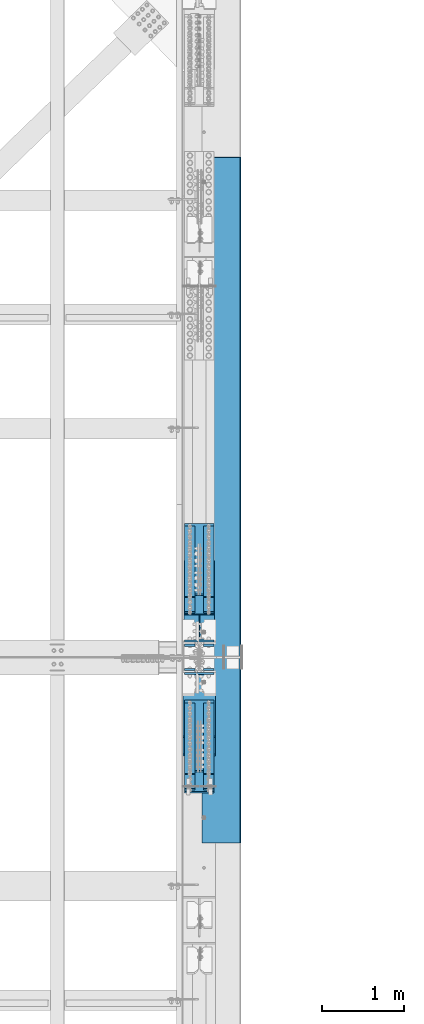
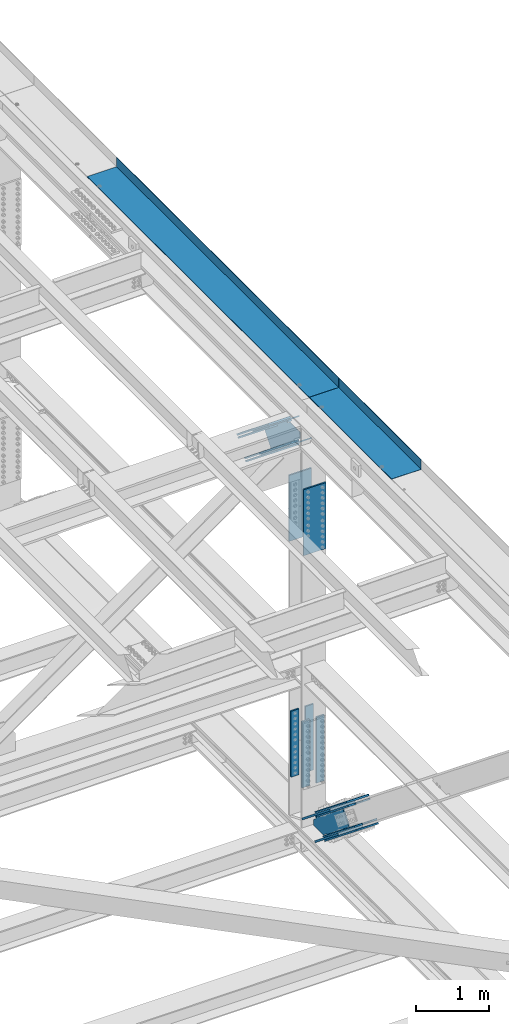
# One storey, part 1966 of 3843: 14 members, 8 beams, 4 elements without a shape of their own.
"""IFC2X3 building model written with IfcOpenShell, lengths in millimetres."""

from ifc_helpers import new_model, si_unit, frame, origin_with_axes, place, context, subcontext, project, spatial, faceted_brep, material, type_object, element, aggregate, save


model = new_model("IFC2X3")

# Units and contexts
model_context = context("Model", 3, precision=1e-05, world=origin_with_axes())
body_context = subcontext(model_context, "Body", "Model", "MODEL_VIEW")
ifc_project = project(units=[si_unit("LENGTHUNIT", "METRE", prefix="MILLI"), si_unit("AREAUNIT", "SQUARE_METRE"), si_unit("VOLUMEUNIT", "CUBIC_METRE"), si_unit("MASSUNIT", "GRAM", prefix="KILO"), si_unit("TIMEUNIT", "SECOND"), si_unit("PLANEANGLEUNIT", "RADIAN"), si_unit("SOLIDANGLEUNIT", "STERADIAN"), si_unit("THERMODYNAMICTEMPERATUREUNIT", "DEGREE_CELSIUS"), si_unit("LUMINOUSINTENSITYUNIT", "LUMEN")], contexts=[model_context])

# Site, building, storey
site_placement = place(None, origin_with_axes())
site = spatial("IfcSite", under=ifc_project, at=site_placement, CompositionType="ELEMENT")
building_placement = place(site_placement, origin_with_axes())
building = spatial("IfcBuilding", under=site, at=building_placement, Name="Undefined", CompositionType="ELEMENT")
storey_placement = place(building_placement, origin_with_axes())
storey = spatial("IfcBuildingStorey", under=building, at=storey_placement, Name="Undefined", CompositionType="ELEMENT", Elevation=0.0)

# Assembly, members
assembly_1_placement = place(storey_placement, origin_with_axes())
assembly_1 = element("IfcElementAssembly", 1, at=assembly_1_placement, inside=storey, Name="BEAM", AssemblyPlace="NOTDEFINED", PredefinedType="RIGID_FRAME")
ifc_material_1 = material(Name="STEEL/A572-50")
member_type_1 = type_object("IfcMemberType", PredefinedType="NOTDEFINED")
member_1_placement = place(assembly_1_placement, frame((85534.5, 43611.4163154636, 44972.4352505098), z_axis=(1.0, 0.0, 0.0), x_axis=(0.0, -0.777700934239512, 0.628634438193605)))
member_1 = element("IfcMember", 2, at=member_1_placement, type_object=member_type_1, material=ifc_material_1, Name="PLATE", context=body_context, shape_type="Brep", body=[
    faceted_brep([(-4.36557456851006e-11, 12.7000000000116, -63.5), (-4.36557456851006e-11, 12.7000000000116, 63.5), (1104.90000001677, 12.7000000017251, 63.5), (1104.90000001677, 12.7000000017251, -63.5), (1.45519152283669e-11, -12.700000000008, 63.5), (1104.90000001682, -12.6999999982909, 63.5), (1.45519152283669e-11, -12.700000000008, -63.5), (1104.90000001682, -12.6999999982909, -63.5)], [[[0, 1, 2, 3]], [[1, 4, 5, 2]], [[4, 6, 7, 5]], [[6, 0, 3, 7]], [[5, 7, 3, 2]], [[6, 4, 1, 0]]]),
])
member_2_placement = place(assembly_1_placement, frame((85534.5, 43797.0363489544, 45202.0708938554), z_axis=(1.0, 0.0, 0.0), x_axis=(0.0, -0.777700934239512, 0.628634438193605)))
member_2 = element("IfcMember", 3, at=member_2_placement, type_object=member_type_1, material=ifc_material_1, Name="PLATE", context=body_context, shape_type="Brep", body=[
    faceted_brep([(-4.36557456851006e-11, 12.7000000000116, -63.5), (-4.36557456851006e-11, 12.7000000000116, 63.5), (1104.90000001677, 12.7000000017251, 63.5), (1104.90000001677, 12.7000000017251, -63.5), (1.45519152283669e-11, -12.700000000008, 63.5), (1104.90000001682, -12.6999999982909, 63.5), (1.45519152283669e-11, -12.700000000008, -63.5), (1104.90000001682, -12.6999999982909, -63.5)], [[[0, 1, 2, 3]], [[1, 4, 5, 2]], [[4, 6, 7, 5]], [[6, 0, 3, 7]], [[5, 7, 3, 2]], [[6, 4, 1, 0]]]),
])
member_3_placement = place(assembly_1_placement, frame((85763.1, 43611.4163154636, 44972.4352505098), z_axis=(1.0, 0.0, 0.0), x_axis=(0.0, -0.777700934239512, 0.628634438193605)))
member_3 = element("IfcMember", 4, at=member_3_placement, type_object=member_type_1, material=ifc_material_1, Name="PLATE", context=body_context, shape_type="Brep", body=[
    faceted_brep([(-4.36557456851006e-11, 12.7000000000116, -63.5), (-4.36557456851006e-11, 12.7000000000116, 63.5), (1104.90000001677, 12.7000000017251, 63.5), (1104.90000001677, 12.7000000017251, -63.5), (1.45519152283669e-11, -12.700000000008, 63.5), (1104.90000001682, -12.6999999982909, 63.5), (1.45519152283669e-11, -12.700000000008, -63.5), (1104.90000001682, -12.6999999982909, -63.5)], [[[0, 1, 2, 3]], [[1, 4, 5, 2]], [[4, 6, 7, 5]], [[6, 0, 3, 7]], [[5, 7, 3, 2]], [[6, 4, 1, 0]]]),
])
member_4_placement = place(assembly_1_placement, frame((85763.1, 43797.0363489544, 45202.0708938554), z_axis=(1.0, 0.0, 0.0), x_axis=(0.0, -0.777700934239512, 0.628634438193605)))
member_4 = element("IfcMember", 5, at=member_4_placement, type_object=member_type_1, material=ifc_material_1, Name="PLATE", context=body_context, shape_type="Brep", body=[
    faceted_brep([(-4.36557456851006e-11, 12.7000000000116, -63.5), (-4.36557456851006e-11, 12.7000000000116, 63.5), (1104.90000001677, 12.7000000017251, 63.5), (1104.90000001677, 12.7000000017251, -63.5), (1.45519152283669e-11, -12.700000000008, 63.5), (1104.90000001682, -12.6999999982909, 63.5), (1.45519152283669e-11, -12.700000000008, -63.5), (1104.90000001682, -12.6999999982909, -63.5)], [[[0, 1, 2, 3]], [[1, 4, 5, 2]], [[4, 6, 7, 5]], [[6, 0, 3, 7]], [[5, 7, 3, 2]], [[6, 4, 1, 0]]]),
])

assembly_2_placement = place(storey_placement, origin_with_axes())
assembly_2 = element("IfcElementAssembly", 6, at=assembly_2_placement, inside=storey, Name="BEAM", AssemblyPlace="NOTDEFINED", PredefinedType="RIGID_FRAME")
member_5_placement = place(assembly_2_placement, frame((85763.1, 40594.7050881366, 40636.5082633832), z_axis=(-1.0, 0.0, 0.0), x_axis=(0.0, 0.778233356227861, -0.62797519318387)))
member_5 = element("IfcMember", 7, at=member_5_placement, type_object=member_type_1, material=ifc_material_1, Name="PLATE", context=body_context, shape_type="Brep", body=[
    faceted_brep([(-4.36557456851006e-11, 12.7000000000116, -63.5), (-4.36557456851006e-11, 12.7000000000116, 63.5), (1104.90000001677, 12.7000000017251, 63.5), (1104.90000001677, 12.7000000017251, -63.5), (1.45519152283669e-11, -12.700000000008, 63.5), (1104.90000001682, -12.6999999982909, 63.5), (1.45519152283669e-11, -12.700000000008, -63.5), (1104.90000001682, -12.6999999982909, -63.5)], [[[0, 1, 2, 3]], [[1, 4, 5, 2]], [[4, 6, 7, 5]], [[6, 0, 3, 7]], [[5, 7, 3, 2]], [[6, 4, 1, 0]]]),
])
member_6_placement = place(assembly_2_placement, frame((85763.1, 40780.1304631424, 40866.3011174421), z_axis=(-1.0, 0.0, 0.0), x_axis=(0.0, 0.778233356227861, -0.62797519318387)))
member_6 = element("IfcMember", 8, at=member_6_placement, type_object=member_type_1, material=ifc_material_1, Name="PLATE", context=body_context, shape_type="Brep", body=[
    faceted_brep([(-4.36557456851006e-11, 12.7000000000116, -63.5), (-4.36557456851006e-11, 12.7000000000116, 63.5), (1104.90000001677, 12.7000000017251, 63.5), (1104.90000001677, 12.7000000017251, -63.5), (1.45519152283669e-11, -12.700000000008, 63.5), (1104.90000001682, -12.6999999982909, 63.5), (1.45519152283669e-11, -12.700000000008, -63.5), (1104.90000001682, -12.6999999982909, -63.5)], [[[0, 1, 2, 3]], [[1, 4, 5, 2]], [[4, 6, 7, 5]], [[6, 0, 3, 7]], [[5, 7, 3, 2]], [[6, 4, 1, 0]]]),
])
member_7_placement = place(assembly_2_placement, frame((85534.5, 40594.7050881365, 40636.508263383), z_axis=(-1.0, 0.0, 0.0), x_axis=(0.0, 0.778233356227861, -0.62797519318387)))
member_7 = element("IfcMember", 9, at=member_7_placement, type_object=member_type_1, material=ifc_material_1, Name="PLATE", context=body_context, shape_type="Brep", body=[
    faceted_brep([(-4.36557456851006e-11, 12.7000000000116, -63.5), (-4.36557456851006e-11, 12.7000000000116, 63.5), (1104.90000001677, 12.7000000017251, 63.5), (1104.90000001677, 12.7000000017251, -63.5), (1.45519152283669e-11, -12.700000000008, 63.5), (1104.90000001682, -12.6999999982909, 63.5), (1.45519152283669e-11, -12.700000000008, -63.5), (1104.90000001682, -12.6999999982909, -63.5)], [[[0, 1, 2, 3]], [[1, 4, 5, 2]], [[4, 6, 7, 5]], [[6, 0, 3, 7]], [[5, 7, 3, 2]], [[6, 4, 1, 0]]]),
])
member_8_placement = place(assembly_2_placement, frame((85534.5, 40780.1304626162, 40866.30111679), z_axis=(-1.0, 0.0, 0.0), x_axis=(0.0, 0.778233356227861, -0.62797519318387)))
member_8 = element("IfcMember", 10, at=member_8_placement, type_object=member_type_1, material=ifc_material_1, Name="PLATE", context=body_context, shape_type="Brep", body=[
    faceted_brep([(-4.36557456851006e-11, 12.7000000000116, -63.5), (-4.36557456851006e-11, 12.7000000000116, 63.5), (1104.90000001677, 12.7000000017251, 63.5), (1104.90000001677, 12.7000000017251, -63.5), (1.45519152283669e-11, -12.700000000008, 63.5), (1104.90000001682, -12.6999999982909, 63.5), (1.45519152283669e-11, -12.700000000008, -63.5), (1104.90000001682, -12.6999999982909, -63.5)], [[[0, 1, 2, 3]], [[1, 4, 5, 2]], [[4, 6, 7, 5]], [[6, 0, 3, 7]], [[5, 7, 3, 2]], [[6, 4, 1, 0]]]),
])

# Member
member_type_2 = type_object("IfcMemberType", PredefinedType="NOTDEFINED")
member_9_placement = place(assembly_1_placement, frame((85648.8, 42724.1917519318, 45632.4446340601), z_axis=(1.0, 0.0, 0.0), x_axis=(0.0, 0.777700934239514, -0.628634438193604)))
member_9 = element("IfcMember", 11, at=member_9_placement, type_object=member_type_2, material=ifc_material_1, Name="PLATE", context=body_context, shape_type="Brep", body=[
    faceted_brep([(-1.45519152283669e-11, 12.7000000000025, -177.800000000003), (-1.45519152283669e-11, 12.7000000000025, 177.800000000003), (1104.90000001682, 12.7000000017051, 177.800000000003), (1104.90000001682, 12.7000000017051, -177.800000000003), (4.36557456851006e-11, -12.7000000000171, 177.800000000003), (1104.90000001686, -12.6999999983072, 177.800000000003), (4.36557456851006e-11, -12.7000000000171, -177.800000000003), (1104.90000001686, -12.6999999983072, -177.800000000003)], [[[0, 1, 2, 3]], [[1, 4, 5, 2]], [[4, 6, 7, 5]], [[6, 0, 3, 7]], [[5, 7, 3, 2]], [[6, 4, 1, 0]]]),
])

member_10_placement = place(assembly_1_placement, frame((85648.8, 42965.6973871403, 45931.2178907486), z_axis=(1.0, 0.0, 0.0), x_axis=(0.0, 0.777700934239514, -0.628634438193604)))
member_10 = element("IfcMember", 12, at=member_10_placement, type_object=member_type_2, material=ifc_material_1, Name="PLATE", context=body_context, shape_type="Brep", body=[
    faceted_brep([(-1.45519152283669e-11, 12.7000000000025, -177.800000000003), (-1.45519152283669e-11, 12.7000000000025, 177.800000000003), (1104.90000001682, 12.7000000017051, 177.800000000003), (1104.90000001682, 12.7000000017051, -177.800000000003), (4.36557456851006e-11, -12.7000000000171, 177.800000000003), (1104.90000001686, -12.6999999983072, 177.800000000003), (4.36557456851006e-11, -12.7000000000171, -177.800000000003), (1104.90000001686, -12.6999999983072, -177.800000000003)], [[[0, 1, 2, 3]], [[1, 4, 5, 2]], [[4, 6, 7, 5]], [[6, 0, 3, 7]], [[5, 7, 3, 2]], [[6, 4, 1, 0]]]),
])

member_11_placement = place(assembly_2_placement, frame((85648.8, 41419.6832516066, 39899.4178813601), z_axis=(-1.0, 0.0, 0.0), x_axis=(0.0, -0.778233356227861, 0.62797519318387)))
member_11 = element("IfcMember", 13, at=member_11_placement, type_object=member_type_2, material=ifc_material_1, Name="PLATE", context=body_context, shape_type="Brep", body=[
    faceted_brep([(-1.45519152283669e-11, 12.7000000000025, -177.800000000003), (-1.45519152283669e-11, 12.7000000000025, 177.800000000003), (1104.90000001682, 12.7000000017051, 177.800000000003), (1104.90000001682, 12.7000000017051, -177.800000000003), (4.36557456851006e-11, -12.7000000000171, 177.800000000003), (1104.90000001686, -12.6999999983072, 177.800000000003), (4.36557456851006e-11, -12.7000000000171, -177.800000000003), (1104.90000001686, -12.6999999983072, -177.800000000003)], [[[0, 1, 2, 3]], [[1, 4, 5, 2]], [[4, 6, 7, 5]], [[6, 0, 3, 7]], [[5, 7, 3, 2]], [[6, 4, 1, 0]]]),
])

member_12_placement = place(assembly_2_placement, frame((85648.8, 41674.892370288, 40215.6919175422), z_axis=(-1.0, 0.0, 0.0), x_axis=(0.0, -0.778233356227861, 0.62797519318387)))
member_12 = element("IfcMember", 14, at=member_12_placement, type_object=member_type_2, material=ifc_material_1, Name="PLATE", context=body_context, shape_type="Brep", body=[
    faceted_brep([(-1.45519152283669e-11, 12.7000000000025, -177.800000000003), (-1.45519152283669e-11, 12.7000000000025, 177.800000000003), (1104.90000001682, 12.7000000017051, 177.800000000003), (1104.90000001682, 12.7000000017051, -177.800000000003), (4.36557456851006e-11, -12.7000000000171, 177.800000000003), (1104.90000001686, -12.6999999983072, 177.800000000003), (4.36557456851006e-11, -12.7000000000171, -177.800000000003), (1104.90000001686, -12.6999999983072, -177.800000000003)], [[[0, 1, 2, 3]], [[1, 4, 5, 2]], [[4, 6, 7, 5]], [[6, 0, 3, 7]], [[5, 7, 3, 2]], [[6, 4, 1, 0]]]),
])

ifc_material_2 = material(Name="STEEL/A992")
member_type_3 = type_object("IfcMemberType", Name="W14X99", PredefinedType="NOTDEFINED")
member_13_placement = place(assembly_1_placement, frame((85648.8, 43274.5854509239, 45434.542167357), z_axis=(0.0, 0.628634438193607, 0.777700934239511), x_axis=(0.0, -0.777700934239512, 0.628634438193605)))
member_13 = element("IfcMember", 15, at=member_13_placement, type_object=member_type_3, material=ifc_material_2, Name="BEAM", ObjectType="W14X99", context=body_context, shape_type="Brep", body=[
    faceted_brep([(981.500451003007, 6.35000000000582, -160.337499995949), (991.140102408519, 6.35000000000582, -160.321113912411), (991.140094901422, 6.35000000000582, -160.33749999592), (981.500451003007, 185.737500000003, -160.337499995949), (991.140094901422, 185.737500000003, -160.33749999592), (6.35000000639411, -185.737500000003, 160.337500001014), (6.35000000639411, -6.35000000000582, 160.337500001014), (802.375273800926, -6.35000000000582, 160.337500003203), (802.375273800926, -185.737500000003, 160.337500003203), (967.470718106835, -6.35000000000582, -131.8375449792), (967.470718106835, 6.35000000000582, -131.8375449792), (1013.46312808303, 6.35000000000582, -131.815463325067), (1029.79451188982, -6.35000000000582, -131.807622379827), (962.434567453738, -6.35000000000582, -133.280667367828), (962.434567453738, 6.35000000000582, -133.280667367828), (958.923286642619, -6.35000000000582, -137.168638907693), (958.923286642619, 6.35000000000582, -137.168638907693), (957.999073580324, -6.35000000000582, -142.325308942192), (957.999073580324, 6.35000000000582, -142.325308942192), (959.941512052095, -6.35000000000582, -147.19073270716), (959.941512052095, 6.35000000000582, -147.19073270716), (6.35000000674336, 185.737500000003, -160.33750000099), (6.35000000674336, 6.35000000000582, -160.33750000099), (970.111951838846, 6.35000000000582, -160.337499996007), (970.111951838846, 185.737500000003, -160.337499996007), (790.036726578202, -6.35000000000582, 142.090542081358), (790.036726578202, 6.35000000000582, 142.090542081358), (791.98765452676, 6.35000000000582, 146.95624624833), (791.98765452676, -6.35000000000582, 146.95624624833), (790.955806607273, -6.35000000000582, 136.929487072819), (790.955806607273, 6.35000000000582, 136.929487072819), (794.466501147186, -6.35000000000582, 133.036387954053), (794.466501147186, 6.35000000000582, 133.036387954053), (799.505405061411, -6.35000000000582, 131.590481925232), (799.505405061411, 6.35000000000582, 131.590481925232), (883.260113658025, -6.35000000000582, 131.5352459325), (863.132796811582, 6.35000000000582, 131.548519840871), (1099.95158527824, -6.35000000000582, -44.9452582842277), (1082.12429502416, 6.35000000000582, -46.805200011353), (6.35000000639411, 6.35000000000582, 160.337500001014), (802.375273800926, 6.35000000000582, 160.337500003203), (6.35000000674336, -6.35000000000582, -160.33750000099), (970.111951838846, -6.35000000000582, -160.337499996007), (970.12690835184, -185.737500000003, -160.356833456499), (970.12690835184, 185.737500000003, -160.356833456499), (970.111951838846, -185.737500000003, -160.337499996007), (6.35000000674336, -185.737500000003, -160.33750000099), (6.35000000674336, -185.737500000003, -179.387500001117), (6.35000000674336, 185.737500000003, -179.387500001117), (991.131367358032, 185.737500000003, -179.387499995908), (991.131367358032, -185.737500000003, -179.387499995908), (981.500451003007, -185.737500000003, -160.337499995949), (991.140094901422, -185.737500000003, -160.33749999592), (981.500451003007, -6.35000000000582, -160.337499995949), (991.140102408519, -6.35000000000582, -160.321113912411), (6.35000000636501, -185.737500000003, 179.387500001133), (6.35000000636501, 185.737500000003, 179.387500001133), (6.35000000639411, 185.737500000003, 160.337500001014), (802.375273800926, 185.737500000003, 160.337500003203), (802.378627628388, 185.737500000003, 160.341820378759), (802.378627628388, -185.737500000003, 160.341820378759), (803.84391907049, 6.35000000000582, 160.33750000321), (803.84391907049, 185.737500000003, 160.33750000321), (824.610855638859, 185.737500000003, 160.337500003297), (824.610855638859, 6.35000000000582, 160.337500003297), (824.610827586645, 6.35000000000582, 160.276269287584), (803.84391907049, -6.35000000000582, 160.33750000321), (803.84391907049, -185.737500000003, 160.33750000321), (824.610827586645, -6.35000000000582, 160.276269287584), (824.610855638859, -6.35000000000582, 160.337500003297), (824.610855638859, -185.737500000003, 160.337500003297), (824.619583196951, -185.737500000003, 179.387500003286), (824.619583196951, 185.737500000003, 179.387500003286), (1094.43355868216, 6.35000000000582, -56.8302602532494), (1102.41343800997, -6.35000000000582, -46.9502703327162), (1102.45010156392, -6.35000000000582, -46.9801303103159), (1094.46047002421, 6.35000000000582, -56.8521777158167), (1072.41307806556, 6.35000000000582, -84.0940971337404), (1072.41311035952, -6.35000000000582, -84.0940572310792)], [[[0, 1, 2]], [[3, 0, 2, 4]], [[5, 6, 7, 8]], [[9, 10, 11, 12]], [[13, 14, 10, 9]], [[15, 16, 14, 13]], [[17, 18, 16, 15]], [[19, 20, 18, 17]], [[21, 22, 23, 24]], [[25, 26, 27, 28]], [[29, 30, 26, 25]], [[31, 32, 30, 29]], [[33, 34, 32, 31]], [[34, 33, 35, 36]], [[36, 35, 37, 38]], [[10, 14, 16, 18, 20, 23, 22, 39, 40, 27, 26, 30, 32, 34, 36, 38, 11]], [[37, 12, 11, 38]], [[35, 33, 31, 29, 25, 28, 7, 6, 41, 42, 19, 17, 15, 13, 9, 12, 37]], [[43, 44, 24, 23, 20, 19, 42, 45]], [[41, 46, 45, 42]], [[47, 48, 49, 50]], [[51, 43, 45, 46, 47, 50, 52]], [[53, 51, 52, 54]], [[1, 0, 3, 44, 43, 51, 53, 54]], [[52, 50, 49, 4, 2, 1, 54]], [[48, 21, 24, 44, 3, 4, 49]], [[47, 46, 41, 6, 5, 55, 56, 57, 39, 22, 21, 48]], [[39, 57, 58, 40]], [[8, 7, 28, 27, 40, 58, 59, 60]], [[61, 62, 63, 64]], [[61, 64, 65]], [[66, 67, 60, 59, 62, 61, 65, 68]], [[66, 68, 69]], [[67, 66, 69, 70]], [[55, 5, 8, 60, 67, 70, 71]], [[56, 55, 71, 72]], [[62, 59, 58, 57, 56, 72, 63]], [[71, 70, 69, 68, 65, 64, 63, 72]], [[73, 74, 75, 76]], [[73, 76, 77]], [[74, 73, 77, 78], [77, 76, 75, 78]], [[74, 78, 75]]]),
])

# Beam
beam_type_1 = type_object("IfcBeamType", PredefinedType="NOTDEFINED")
beam_1_placement = place(assembly_2_placement, frame((85763.1, 42054.4624999998, 41508.7843177339), z_axis=(-1.0, 0.0, 0.0), x_axis=(0.0, 0.0, -1.0)))
beam_1 = element("IfcBeam", 16, at=beam_1_placement, type_object=beam_type_1, material=ifc_material_1, Name="PLATE", context=body_context, shape_type="Brep", body=[
    faceted_brep([(-4.36557456851006e-11, 12.7000000000116, -63.5), (-4.36557456851006e-11, 12.7000000000116, 63.5), (1104.90000001677, 12.7000000017251, 63.5), (1104.90000001677, 12.7000000017251, -63.5), (1.45519152283669e-11, -12.700000000008, 63.5), (1104.90000001682, -12.6999999982909, 63.5), (1.45519152283669e-11, -12.700000000008, -63.5), (1104.90000001682, -12.6999999982909, -63.5)], [[[0, 1, 2, 3]], [[1, 4, 5, 2]], [[4, 6, 7, 5]], [[6, 0, 3, 7]], [[5, 7, 3, 2]], [[6, 4, 1, 0]]]),
])

beam_2_placement = place(assembly_2_placement, frame((85763.1, 42349.7374999998, 41508.7843177339), z_axis=(-1.0, 0.0, 0.0), x_axis=(0.0, 0.0, -1.0)))
beam_2 = element("IfcBeam", 17, at=beam_2_placement, type_object=beam_type_1, material=ifc_material_1, Name="PLATE", context=body_context, shape_type="Brep", body=[
    faceted_brep([(-4.36557456851006e-11, 12.7000000000116, -63.5), (-4.36557456851006e-11, 12.7000000000116, 63.5), (1104.90000001677, 12.7000000017251, 63.5), (1104.90000001677, 12.7000000017251, -63.5), (1.45519152283669e-11, -12.700000000008, 63.5), (1104.90000001682, -12.6999999982909, 63.5), (1.45519152283669e-11, -12.700000000008, -63.5), (1104.90000001682, -12.6999999982909, -63.5)], [[[0, 1, 2, 3]], [[1, 4, 5, 2]], [[4, 6, 7, 5]], [[6, 0, 3, 7]], [[5, 7, 3, 2]], [[6, 4, 1, 0]]]),
])

beam_3_placement = place(assembly_2_placement, frame((85534.5, 42054.4624999998, 41508.7843177339), z_axis=(-1.0, 0.0, 0.0), x_axis=(0.0, 0.0, -1.0)))
beam_3 = element("IfcBeam", 18, at=beam_3_placement, type_object=beam_type_1, material=ifc_material_1, Name="PLATE", context=body_context, shape_type="Brep", body=[
    faceted_brep([(-4.36557456851006e-11, 12.7000000000116, -63.5), (-4.36557456851006e-11, 12.7000000000116, 63.5), (1104.90000001677, 12.7000000017251, 63.5), (1104.90000001677, 12.7000000017251, -63.5), (1.45519152283669e-11, -12.700000000008, 63.5), (1104.90000001682, -12.6999999982909, 63.5), (1.45519152283669e-11, -12.700000000008, -63.5), (1104.90000001682, -12.6999999982909, -63.5)], [[[0, 1, 2, 3]], [[1, 4, 5, 2]], [[4, 6, 7, 5]], [[6, 0, 3, 7]], [[5, 7, 3, 2]], [[6, 4, 1, 0]]]),
])

beam_4_placement = place(assembly_2_placement, frame((85534.5, 42349.7374999998, 41508.7843177339), z_axis=(-1.0, 0.0, 0.0), x_axis=(0.0, 0.0, -1.0)))
beam_4 = element("IfcBeam", 19, at=beam_4_placement, type_object=beam_type_1, material=ifc_material_1, Name="PLATE", context=body_context, shape_type="Brep", body=[
    faceted_brep([(-4.36557456851006e-11, 12.7000000000116, -63.5), (-4.36557456851006e-11, 12.7000000000116, 63.5), (1104.90000001677, 12.7000000017251, 63.5), (1104.90000001677, 12.7000000017251, -63.5), (1.45519152283669e-11, -12.700000000008, 63.5), (1104.90000001682, -12.6999999982909, 63.5), (1.45519152283669e-11, -12.700000000008, -63.5), (1104.90000001682, -12.6999999982909, -63.5)], [[[0, 1, 2, 3]], [[1, 4, 5, 2]], [[4, 6, 7, 5]], [[6, 0, 3, 7]], [[5, 7, 3, 2]], [[6, 4, 1, 0]]]),
])

beam_type_2 = type_object("IfcBeamType", PredefinedType="NOTDEFINED")
beam_5_placement = place(assembly_1_placement, frame((85648.8, 42003.6624999926, 45426.7656721454), z_axis=(1.0, 0.0, 0.0), x_axis=(0.0, 0.0, -1.0)))
beam_5 = element("IfcBeam", 20, at=beam_5_placement, type_object=beam_type_2, material=ifc_material_1, Name="PLATE", context=body_context, shape_type="Brep", body=[
    faceted_brep([(-1.45519152283669e-11, 12.7000000000025, -177.800000000003), (-1.45519152283669e-11, 12.7000000000025, 177.800000000003), (1104.90000001682, 12.7000000017051, 177.800000000003), (1104.90000001682, 12.7000000017051, -177.800000000003), (4.36557456851006e-11, -12.7000000000171, 177.800000000003), (1104.90000001686, -12.6999999983072, 177.800000000003), (4.36557456851006e-11, -12.7000000000171, -177.800000000003), (1104.90000001686, -12.6999999983072, -177.800000000003)], [[[0, 1, 2, 3]], [[1, 4, 5, 2]], [[4, 6, 7, 5]], [[6, 0, 3, 7]], [[5, 7, 3, 2]], [[6, 4, 1, 0]]]),
])

beam_6_placement = place(assembly_1_placement, frame((85648.8, 42400.5374999998, 45426.7656721454), z_axis=(1.0, 0.0, 0.0), x_axis=(0.0, 0.0, -1.0)))
beam_6 = element("IfcBeam", 21, at=beam_6_placement, type_object=beam_type_2, material=ifc_material_1, Name="PLATE", context=body_context, shape_type="Brep", body=[
    faceted_brep([(-1.45519152283669e-11, 12.7000000000025, -177.800000000003), (-1.45519152283669e-11, 12.7000000000025, 177.800000000003), (1104.90000001682, 12.7000000017051, 177.800000000003), (1104.90000001682, 12.7000000017051, -177.800000000003), (4.36557456851006e-11, -12.7000000000171, 177.800000000003), (1104.90000001686, -12.6999999983072, 177.800000000003), (4.36557456851006e-11, -12.7000000000171, -177.800000000003), (1104.90000001686, -12.6999999983072, -177.800000000003)], [[[0, 1, 2, 3]], [[1, 4, 5, 2]], [[4, 6, 7, 5]], [[6, 0, 3, 7]], [[5, 7, 3, 2]], [[6, 4, 1, 0]]]),
])

aggregate(assembly_1, [member_1, member_2, member_3, member_4, member_9, member_10, member_13, beam_5, beam_6])

# Member
member_type_4 = type_object("IfcMemberType", Name="W14X159", PredefinedType="NOTDEFINED")
member_14_placement = place(assembly_2_placement, frame((85648.8, 42202.1, 39529.1712115785), z_axis=(0.0, 0.627975193183871, 0.77823335622786), x_axis=(0.0, -0.778233356227861, 0.62797519318387)))
member_14 = element("IfcMember", 22, at=member_14_placement, type_object=member_type_4, material=ifc_material_2, Name="BEAM", ObjectType="W14X159", context=body_context, shape_type="Brep", body=[
    faceted_brep([(1387.50853605251, -9.52499999999418, 160.337500009824), (1387.50853605251, -198.4375, 160.337500009824), (418.839349065983, -198.4375, 160.337500001297), (418.839349065983, -9.52499999999418, 160.337500001297), (1387.50853605266, -198.4375, 190.500000009892), (1387.50853605266, 198.4375, 190.500000009892), (397.497209167791, 198.4375, 190.500000001317), (397.497209167791, -198.4375, 190.500000001317), (418.789233499326, -198.4375, 160.402850160783), (396.564233711407, -198.4375, 160.399379561997), (418.789233499326, 198.4375, 160.402850160783), (396.564233711407, 198.4375, 160.399379561997), (1387.50853605251, 198.4375, 160.337500009824), (418.839349065983, 198.4375, 160.337500001297), (608.499872034829, -9.52499999999418, -137.469949889921), (608.499872034829, 9.52499999999418, -137.469949889921), (591.010458245192, 9.52499999999418, -160.245274022593), (591.010458245192, -9.52499999999418, -160.245274022593), (610.424224937472, -9.52499999999418, -132.604576946593), (610.424224937472, 9.52499999999418, -132.604576946593), (609.48846908623, -9.52499999999418, -127.456825111243), (609.48846908623, 9.52499999999418, -127.456825111243), (605.97495367654, -9.52499999999418, -123.579945252728), (605.97495367654, 9.52499999999418, -123.579945252728), (600.943825164063, -9.52499999999418, -122.143723172943), (600.943825164063, 9.52499999999418, -122.143723172943), (484.884630707284, -9.52499999999418, -122.161843421425), (515.068141856099, 9.52499999915017, -122.157130888962), (279.233838316212, -9.52499999999418, 45.1167506597412), (305.973054777433, 9.52499999993597, 47.9230899996983), (365.96605208818, 9.52499999591964, 122.294602771683), (341.487532503545, -9.52499999999418, 122.29078129492), (428.699665727515, -9.52499999999418, 122.304396462256), (428.699665727515, 9.52499999999418, 122.304396462256), (433.728399788713, -9.52499999999418, 123.740978460322), (433.728399788713, 9.52499999999418, 123.740978460322), (437.240624315592, -9.52499999999418, 127.616054326441), (437.240624315592, 9.52499999999418, 127.616054326441), (438.177474830979, -9.52499999999418, 132.761367262239), (438.177474830979, 9.52499999999418, 132.761367262239), (436.256509901082, -9.52499999999418, 137.625709749518), (436.256509901082, 9.52499999999418, 137.625709749518), (418.839349065983, 9.52499999999418, 160.337500001297), (1387.50853605251, 9.52499999999418, 160.337500009824), (1387.50853605104, 9.52499999999418, -160.337499990877), (1387.50853605104, 198.4375, -160.337499990877), (568.785472385974, 198.4375, -160.33749999907), (568.785472385974, 9.52499999999418, -160.33749999907), (568.785458533536, 9.52499999999418, -160.248745332698), (568.785458533536, -9.52499999999418, -160.248745332698), (1387.50853605104, -9.52499999999418, -160.337499990877), (568.785472385974, -9.52499999999418, -160.33749999907), (1387.50853605104, -198.4375, -160.337499990877), (568.785472385974, -198.4375, -160.33749999907), (1387.50853605091, -198.4375, -190.499999990952), (1387.50853605091, 198.4375, -190.499999990952), (568.453791740506, 198.4375, -190.499999999134), (568.790166162867, 198.4375, -190.411242444694), (568.790166162867, -198.4375, -190.411242444694), (568.453791740506, -198.4375, -190.499999999134)], [[[0, 1, 2, 3]], [[4, 5, 6, 7]], [[8, 2, 1, 4, 7, 9]], [[10, 8, 9, 11]], [[7, 6, 11, 9]], [[5, 12, 13, 10, 11, 6]], [[14, 15, 16, 17]], [[18, 19, 15, 14]], [[20, 21, 19, 18]], [[22, 23, 21, 20]], [[24, 25, 23, 22]], [[25, 24, 26, 27]], [[27, 26, 28, 29]], [[30, 29, 28, 31]], [[32, 33, 30, 31]], [[34, 35, 33, 32]], [[36, 37, 35, 34]], [[38, 39, 37, 36]], [[40, 41, 39, 38]], [[3, 2, 8, 10, 13, 42, 41, 40]], [[12, 43, 42, 13]], [[44, 45, 46, 47]], [[16, 15, 19, 21, 23, 25, 27, 29, 30, 33, 35, 37, 39, 41, 42, 43, 44, 47, 48]], [[17, 16, 48, 49]], [[50, 0, 3, 40, 38, 36, 34, 32, 31, 28, 26, 24, 22, 20, 18, 14, 17, 49, 51]], [[52, 50, 51, 53]], [[44, 43, 12, 5, 4, 1, 0, 50, 52, 54, 55, 45]], [[45, 55, 56, 57, 46]], [[53, 51, 49, 48, 47, 46, 57, 58]], [[54, 52, 53, 58, 59]], [[55, 54, 59, 56]], [[58, 57, 56, 59]]]),
])

aggregate(assembly_2, [member_5, member_6, member_7, member_8, member_11, member_12, beam_1, beam_2, beam_3, beam_4, member_14])

# Assembly, beam
assembly_3_placement = place(storey_placement, origin_with_axes())
assembly_3 = element("IfcElementAssembly", 23, at=assembly_3_placement, inside=storey, Name="BEAM", AssemblyPlace="NOTDEFINED", PredefinedType="RIGID_FRAME")
ifc_material_3 = material(Name="STEEL/A36")
beam_type_3 = type_object("IfcBeamType", PredefinedType="NOTDEFINED")
beam_7_placement = place(assembly_3_placement, frame((85680.5500000008, 41071.8, 46772.5124999998), z_axis=(0.0, -1.0, 0.0), x_axis=(1.0, 0.0, 0.0)))
beam_7 = element("IfcBeam", 24, at=beam_7_placement, type_object=beam_type_3, material=ifc_material_3, Name="BENT_PLATE", context=body_context, shape_type="Brep", body=[
    faceted_brep([(466.724999999991, 4.76249999999709, -1127.12500004766), (469.899998426787, 1.58750004768081, -1130.3), (0.0, 1.58750004768081, -1130.3), (0.0, 4.76249999999709, -1127.12500004766), (466.725000000006, 160.337499999994, -1127.12500004766), (469.899998426801, 160.337499999994, -1130.3), (0.0, 4.76249999999709, 1130.3), (466.724999999991, 4.76249999999709, 1130.3), (0.0, -4.76249999999709, -1130.3), (0.0, -4.76249999999709, 1130.3), (476.249999999985, -4.76249999999709, -1130.3), (476.249999999985, -4.76249999999709, 1130.3), (466.725000000006, 160.337499999994, 1130.3), (476.25, 160.337499999994, 1130.3), (476.25, 160.337499999994, -1130.3)], [[[0, 1, 2, 3]], [[4, 5, 1, 0]], [[6, 7, 0, 3]], [[8, 9, 6, 3, 2]], [[9, 8, 10, 11]], [[7, 12, 4, 0]], [[7, 6, 9, 11, 13, 12]], [[11, 10, 14, 13]], [[5, 14, 10, 8, 2, 1]], [[12, 13, 14, 5, 4]]]),
])
aggregate(assembly_3, [beam_7])

assembly_4_placement = place(storey_placement, origin_with_axes())
assembly_4 = element("IfcElementAssembly", 25, at=assembly_4_placement, inside=storey, Name="BEAM", AssemblyPlace="NOTDEFINED", PredefinedType="RIGID_FRAME")
beam_8_placement = place(assembly_4_placement, frame((85680.5500000013, 45250.1, 46772.5124999999), z_axis=(0.0, -1.0, 0.0), x_axis=(1.0, 0.0, 0.0)))
beam_8 = element("IfcBeam", 26, at=beam_8_placement, type_object=beam_type_3, material=ifc_material_3, Name="BENT_PLATE", context=body_context, shape_type="Brep", body=[
    faceted_brep([(466.724998474107, 4.76249999999709, -3044.82500004767), (469.899999921181, 1.58750004768081, -3048.0), (0.0, 1.58750004768081, -3048.0), (0.0, 4.76249999999709, -3044.82500004768), (466.725000000006, 160.337499999994, -3044.82500004767), (469.900001478221, 160.337499968853, -3048.0), (0.0, 4.76249999999709, 3048.0), (466.724998474107, 4.76249999999709, 3048.0), (0.0, -4.76249999999709, -3048.0), (0.0, -4.76249999999709, 3048.0), (476.249998380677, -4.76249999999709, -3048.0), (476.249998380677, -4.76249999999709, 3048.0), (466.725000000006, 160.337499999994, 3048.0), (476.25, 160.337499906571, 3048.0), (476.25, 160.337499906571, -3048.0)], [[[0, 1, 2, 3]], [[4, 5, 1, 0]], [[6, 7, 0, 3]], [[8, 9, 6, 3, 2]], [[9, 8, 10, 11]], [[7, 12, 4, 0]], [[7, 6, 9, 11, 13, 12]], [[11, 10, 14, 13]], [[5, 14, 10, 8, 2, 1]], [[12, 13, 14, 5, 4]]]),
])
aggregate(assembly_4, [beam_8])

save(model, "model.ifc")
